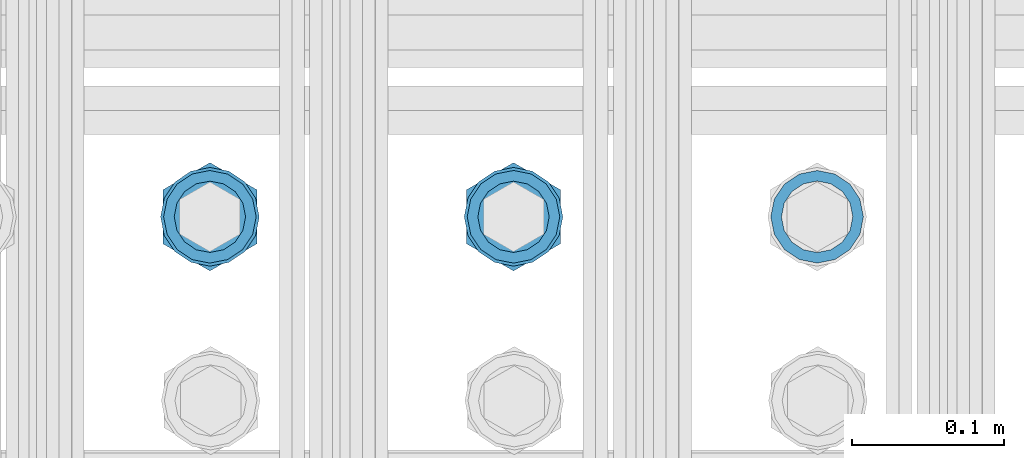
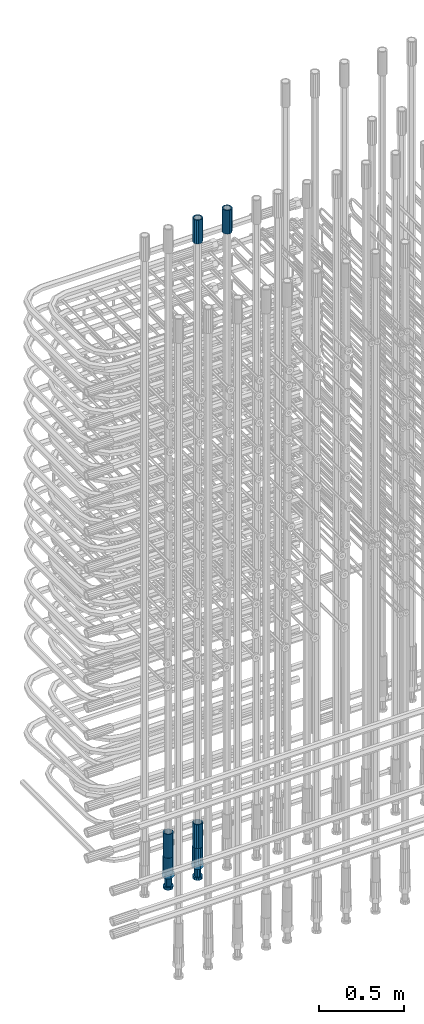
# One storey, part 33 of 177: 6 beams.
"""IFC2X3 building model written with IfcOpenShell, lengths in millimetres."""

from ifc_helpers import new_model, si_unit, frame, origin_with_axes, place, context, subcontext, project, spatial, faceted_brep, material, type_object, element, save


model = new_model("IFC2X3")

# Units and contexts
model_context_1 = context("Model", 3, precision=1e-05, world=origin_with_axes())
model_context_2 = context("Model", 3, precision=1e-05, world=origin_with_axes())
body_context = subcontext(model_context_2, "Body", "Model", "MODEL_VIEW")
ifc_project = project(units=[si_unit("LENGTHUNIT", "METRE", prefix="MILLI"), si_unit("AREAUNIT", "SQUARE_METRE"), si_unit("VOLUMEUNIT", "CUBIC_METRE"), si_unit("MASSUNIT", "GRAM", prefix="KILO"), si_unit("TIMEUNIT", "SECOND"), si_unit("PLANEANGLEUNIT", "RADIAN"), si_unit("SOLIDANGLEUNIT", "STERADIAN"), si_unit("THERMODYNAMICTEMPERATUREUNIT", "DEGREE_CELSIUS"), si_unit("LUMINOUSINTENSITYUNIT", "LUMEN")], contexts=[model_context_1])

# Site, building, storey
site_placement = place(None, origin_with_axes())
site = spatial("IfcSite", under=ifc_project, at=site_placement, CompositionType="ELEMENT")
building_placement = place(site_placement, origin_with_axes())
building = spatial("IfcBuilding", under=site, at=building_placement, Name="Undefined", CompositionType="ELEMENT")
storey_placement = place(building_placement, origin_with_axes())
storey = spatial("IfcBuildingStorey", under=building, at=storey_placement, Name="Undefined", CompositionType="ELEMENT", Elevation=0.0)

# Beams
ifc_material = material(Name="STEEL/S275")
beam_type_1 = type_object("IfcBeamType", PredefinedType="NOTDEFINED")
beam_1_placement = place(storey_placement, frame((2030635.50306268, 6205277.49272666, 23229.9858194793), z_axis=(1.0, 0.0, 0.0), x_axis=(0.0, 0.0, 1.0)))
element("IfcBeam", 1, at=beam_1_placement, inside=storey, type_object=beam_type_1, material=ifc_material, Name="AG40N", context=body_context, shape_type="Brep", body=[
    faceted_brep([(0.0, -23.5000000001164, -9.31322574615479e-10), (0.0, -21.7111690140155, 8.99306066054851), (170.0, -21.7111690140155, 8.99306066054851), (170.0, -23.5, 0.0), (0.0, -16.6170093578839, 16.6170093575493), (170.0, -16.6170093578839, 16.6170093575493), (0.0, -8.99306066057943, 21.7111690137535), (170.0, -8.99306066057943, 21.7111690137535), (0.0, 1.16415321826935e-10, 23.5), (170.0, 0.0, 23.5), (0.0, 8.99306066057943, 21.7111690137535), (170.0, 8.99306066057943, 21.7111690137535), (0.0, 16.6170093578839, 16.6170093575493), (170.0, 16.6170093578839, 16.6170093575493), (0.0, 21.7111690140155, 8.99306066054851), (170.0, 21.7111690140155, 8.99306066054851), (0.0, 23.5000000001164, -9.31322574615479e-10), (170.0, 23.5, 0.0), (0.0, 21.7111690140155, -8.99306066054851), (170.0, 21.7111690140155, -8.99306066054851), (0.0, 16.6170093578839, -16.6170093575493), (170.0, 16.6170093578839, -16.6170093575493), (0.0, 8.99306066057943, -21.7111690137535), (170.0, 8.99306066057943, -21.7111690137535), (0.0, 1.16415321826935e-10, -23.5000000009313), (170.0, 0.0, -23.5), (0.0, -8.99306066057943, -21.7111690137535), (170.0, -8.99306066057943, -21.7111690137535), (0.0, -16.6170093578839, -16.6170093575493), (170.0, -16.6170093578839, -16.6170093575493), (0.0, -21.7111690140155, -8.99306066054851), (170.0, -21.7111690140155, -8.99306066054851), (0.0, -30.5, 0.0), (0.0, -28.1783257415937, -11.6718446873128), (170.0, -28.1783257415937, -11.6718446873128), (170.0, -30.5, 0.0), (0.0, -21.5667568261888, -21.5667568258941), (170.0, -21.5667568261888, -21.5667568258941), (0.0, -11.6718446871346, -28.1783257415518), (170.0, -11.6718446871346, -28.1783257415518), (0.0, 0.0, -30.5), (170.0, 0.0, -30.5), (0.0, 11.6718446871346, -28.1783257415518), (170.0, 11.6718446871346, -28.1783257415518), (0.0, 21.5667568261888, -21.5667568258941), (170.0, 21.5667568261888, -21.5667568258941), (0.0, 28.1783257415937, -11.6718446873128), (170.0, 28.1783257415937, -11.6718446873128), (0.0, 30.5, 0.0), (170.0, 30.5, 0.0), (0.0, 28.1783257415937, 11.6718446873128), (170.0, 28.1783257415937, 11.6718446873128), (0.0, 21.5667568261888, 21.5667568258941), (170.0, 21.5667568261888, 21.5667568258941), (0.0, 11.6718446871346, 28.1783257415518), (170.0, 11.6718446871346, 28.1783257415518), (0.0, 0.0, 30.5), (170.0, 0.0, 30.5), (0.0, -11.6718446871346, 28.1783257415518), (170.0, -11.6718446871346, 28.1783257415518), (0.0, -21.5667568261888, 21.5667568258941), (170.0, -21.5667568261888, 21.5667568258941), (0.0, -28.1783257415937, 11.6718446873128), (170.0, -28.1783257415937, 11.6718446873128)], [[[0, 1, 2, 3]], [[1, 4, 5, 2]], [[4, 6, 7, 5]], [[6, 8, 9, 7]], [[8, 10, 11, 9]], [[10, 12, 13, 11]], [[12, 14, 15, 13]], [[14, 16, 17, 15]], [[16, 18, 19, 17]], [[18, 20, 21, 19]], [[20, 22, 23, 21]], [[22, 24, 25, 23]], [[24, 26, 27, 25]], [[26, 28, 29, 27]], [[28, 30, 31, 29]], [[30, 0, 3, 31]], [[32, 33, 34, 35]], [[33, 36, 37, 34]], [[36, 38, 39, 37]], [[38, 40, 41, 39]], [[40, 42, 43, 41]], [[42, 44, 45, 43]], [[44, 46, 47, 45]], [[46, 48, 49, 47]], [[48, 50, 51, 49]], [[50, 52, 53, 51]], [[52, 54, 55, 53]], [[54, 56, 57, 55]], [[56, 58, 59, 57]], [[58, 60, 61, 59]], [[60, 62, 63, 61]], [[62, 32, 35, 63]], [[37, 39, 41, 43, 45, 47, 49, 51, 53, 55, 57, 59, 61, 63, 35, 34], [5, 7, 9, 11, 13, 15, 17, 19, 21, 23, 25, 27, 29, 31, 3, 2]], [[62, 60, 58, 56, 54, 52, 50, 48, 46, 44, 42, 40, 38, 36, 33, 32], [30, 28, 26, 24, 22, 20, 18, 16, 14, 12, 10, 8, 6, 4, 1, 0]]]),
])
beam_2_placement = place(storey_placement, frame((2030435.5030627, 6205277.49272666, 19060.966800425), z_axis=(-1.0, 0.0, 0.0), x_axis=(0.0, 0.0, -1.0)))
element("IfcBeam", 2, at=beam_2_placement, inside=storey, type_object=beam_type_1, material=ifc_material, Name="AG40N", context=body_context, shape_type="Brep", body=[
    faceted_brep([(0.0, -23.5000000001164, -9.31322574615479e-10), (0.0, -21.7111690140155, 8.99306066054851), (170.0, -21.7111690140155, 8.99306066054851), (170.0, -23.5, 0.0), (0.0, -16.6170093578839, 16.6170093575493), (170.0, -16.6170093578839, 16.6170093575493), (0.0, -8.99306066057943, 21.7111690137535), (170.0, -8.99306066057943, 21.7111690137535), (0.0, 1.16415321826935e-10, 23.5), (170.0, 0.0, 23.5), (0.0, 8.99306066057943, 21.7111690137535), (170.0, 8.99306066057943, 21.7111690137535), (0.0, 16.6170093578839, 16.6170093575493), (170.0, 16.6170093578839, 16.6170093575493), (0.0, 21.7111690140155, 8.99306066054851), (170.0, 21.7111690140155, 8.99306066054851), (0.0, 23.5000000001164, -9.31322574615479e-10), (170.0, 23.5, 0.0), (0.0, 21.7111690140155, -8.99306066054851), (170.0, 21.7111690140155, -8.99306066054851), (0.0, 16.6170093578839, -16.6170093575493), (170.0, 16.6170093578839, -16.6170093575493), (0.0, 8.99306066057943, -21.7111690137535), (170.0, 8.99306066057943, -21.7111690137535), (0.0, 1.16415321826935e-10, -23.5000000009313), (170.0, 0.0, -23.5), (0.0, -8.99306066057943, -21.7111690137535), (170.0, -8.99306066057943, -21.7111690137535), (0.0, -16.6170093578839, -16.6170093575493), (170.0, -16.6170093578839, -16.6170093575493), (0.0, -21.7111690140155, -8.99306066054851), (170.0, -21.7111690140155, -8.99306066054851), (0.0, -30.5, 0.0), (0.0, -28.1783257415937, -11.6718446873128), (170.0, -28.1783257415937, -11.6718446873128), (170.0, -30.5, 0.0), (0.0, -21.5667568261888, -21.5667568258941), (170.0, -21.5667568261888, -21.5667568258941), (0.0, -11.6718446871346, -28.1783257415518), (170.0, -11.6718446871346, -28.1783257415518), (0.0, 0.0, -30.5), (170.0, 0.0, -30.5), (0.0, 11.6718446871346, -28.1783257415518), (170.0, 11.6718446871346, -28.1783257415518), (0.0, 21.5667568261888, -21.5667568258941), (170.0, 21.5667568261888, -21.5667568258941), (0.0, 28.1783257415937, -11.6718446873128), (170.0, 28.1783257415937, -11.6718446873128), (0.0, 30.5, 0.0), (170.0, 30.5, 0.0), (0.0, 28.1783257415937, 11.6718446873128), (170.0, 28.1783257415937, 11.6718446873128), (0.0, 21.5667568261888, 21.5667568258941), (170.0, 21.5667568261888, 21.5667568258941), (0.0, 11.6718446871346, 28.1783257415518), (170.0, 11.6718446871346, 28.1783257415518), (0.0, 0.0, 30.5), (170.0, 0.0, 30.5), (0.0, -11.6718446871346, 28.1783257415518), (170.0, -11.6718446871346, 28.1783257415518), (0.0, -21.5667568261888, 21.5667568258941), (170.0, -21.5667568261888, 21.5667568258941), (0.0, -28.1783257415937, 11.6718446873128), (170.0, -28.1783257415937, 11.6718446873128)], [[[0, 1, 2, 3]], [[1, 4, 5, 2]], [[4, 6, 7, 5]], [[6, 8, 9, 7]], [[8, 10, 11, 9]], [[10, 12, 13, 11]], [[12, 14, 15, 13]], [[14, 16, 17, 15]], [[16, 18, 19, 17]], [[18, 20, 21, 19]], [[20, 22, 23, 21]], [[22, 24, 25, 23]], [[24, 26, 27, 25]], [[26, 28, 29, 27]], [[28, 30, 31, 29]], [[30, 0, 3, 31]], [[32, 33, 34, 35]], [[33, 36, 37, 34]], [[36, 38, 39, 37]], [[38, 40, 41, 39]], [[40, 42, 43, 41]], [[42, 44, 45, 43]], [[44, 46, 47, 45]], [[46, 48, 49, 47]], [[48, 50, 51, 49]], [[50, 52, 53, 51]], [[52, 54, 55, 53]], [[54, 56, 57, 55]], [[56, 58, 59, 57]], [[58, 60, 61, 59]], [[60, 62, 63, 61]], [[62, 32, 35, 63]], [[37, 39, 41, 43, 45, 47, 49, 51, 53, 55, 57, 59, 61, 63, 35, 34], [5, 7, 9, 11, 13, 15, 17, 19, 21, 23, 25, 27, 29, 31, 3, 2]], [[62, 60, 58, 56, 54, 52, 50, 48, 46, 44, 42, 40, 38, 36, 33, 32], [30, 28, 26, 24, 22, 20, 18, 16, 14, 12, 10, 8, 6, 4, 1, 0]]]),
])
beam_3_placement = place(storey_placement, frame((2030435.50306268, 6205277.49272666, 23229.9858194793), z_axis=(1.0, 0.0, 0.0), x_axis=(0.0, 0.0, 1.0)))
element("IfcBeam", 3, at=beam_3_placement, inside=storey, type_object=beam_type_1, material=ifc_material, Name="AG40N", context=body_context, shape_type="Brep", body=[
    faceted_brep([(0.0, -23.5000000001164, -9.31322574615479e-10), (0.0, -21.7111690140155, 8.99306066054851), (170.0, -21.7111690140155, 8.99306066054851), (170.0, -23.5, 0.0), (0.0, -16.6170093578839, 16.6170093575493), (170.0, -16.6170093578839, 16.6170093575493), (0.0, -8.99306066057943, 21.7111690137535), (170.0, -8.99306066057943, 21.7111690137535), (0.0, 1.16415321826935e-10, 23.5), (170.0, 0.0, 23.5), (0.0, 8.99306066057943, 21.7111690137535), (170.0, 8.99306066057943, 21.7111690137535), (0.0, 16.6170093578839, 16.6170093575493), (170.0, 16.6170093578839, 16.6170093575493), (0.0, 21.7111690140155, 8.99306066054851), (170.0, 21.7111690140155, 8.99306066054851), (0.0, 23.5000000001164, -9.31322574615479e-10), (170.0, 23.5, 0.0), (0.0, 21.7111690140155, -8.99306066054851), (170.0, 21.7111690140155, -8.99306066054851), (0.0, 16.6170093578839, -16.6170093575493), (170.0, 16.6170093578839, -16.6170093575493), (0.0, 8.99306066057943, -21.7111690137535), (170.0, 8.99306066057943, -21.7111690137535), (0.0, 1.16415321826935e-10, -23.5000000009313), (170.0, 0.0, -23.5), (0.0, -8.99306066057943, -21.7111690137535), (170.0, -8.99306066057943, -21.7111690137535), (0.0, -16.6170093578839, -16.6170093575493), (170.0, -16.6170093578839, -16.6170093575493), (0.0, -21.7111690140155, -8.99306066054851), (170.0, -21.7111690140155, -8.99306066054851), (0.0, -30.5, 0.0), (0.0, -28.1783257415937, -11.6718446873128), (170.0, -28.1783257415937, -11.6718446873128), (170.0, -30.5, 0.0), (0.0, -21.5667568261888, -21.5667568258941), (170.0, -21.5667568261888, -21.5667568258941), (0.0, -11.6718446871346, -28.1783257415518), (170.0, -11.6718446871346, -28.1783257415518), (0.0, 0.0, -30.5), (170.0, 0.0, -30.5), (0.0, 11.6718446871346, -28.1783257415518), (170.0, 11.6718446871346, -28.1783257415518), (0.0, 21.5667568261888, -21.5667568258941), (170.0, 21.5667568261888, -21.5667568258941), (0.0, 28.1783257415937, -11.6718446873128), (170.0, 28.1783257415937, -11.6718446873128), (0.0, 30.5, 0.0), (170.0, 30.5, 0.0), (0.0, 28.1783257415937, 11.6718446873128), (170.0, 28.1783257415937, 11.6718446873128), (0.0, 21.5667568261888, 21.5667568258941), (170.0, 21.5667568261888, 21.5667568258941), (0.0, 11.6718446871346, 28.1783257415518), (170.0, 11.6718446871346, 28.1783257415518), (0.0, 0.0, 30.5), (170.0, 0.0, 30.5), (0.0, -11.6718446871346, 28.1783257415518), (170.0, -11.6718446871346, 28.1783257415518), (0.0, -21.5667568261888, 21.5667568258941), (170.0, -21.5667568261888, 21.5667568258941), (0.0, -28.1783257415937, 11.6718446873128), (170.0, -28.1783257415937, 11.6718446873128)], [[[0, 1, 2, 3]], [[1, 4, 5, 2]], [[4, 6, 7, 5]], [[6, 8, 9, 7]], [[8, 10, 11, 9]], [[10, 12, 13, 11]], [[12, 14, 15, 13]], [[14, 16, 17, 15]], [[16, 18, 19, 17]], [[18, 20, 21, 19]], [[20, 22, 23, 21]], [[22, 24, 25, 23]], [[24, 26, 27, 25]], [[26, 28, 29, 27]], [[28, 30, 31, 29]], [[30, 0, 3, 31]], [[32, 33, 34, 35]], [[33, 36, 37, 34]], [[36, 38, 39, 37]], [[38, 40, 41, 39]], [[40, 42, 43, 41]], [[42, 44, 45, 43]], [[44, 46, 47, 45]], [[46, 48, 49, 47]], [[48, 50, 51, 49]], [[50, 52, 53, 51]], [[52, 54, 55, 53]], [[54, 56, 57, 55]], [[56, 58, 59, 57]], [[58, 60, 61, 59]], [[60, 62, 63, 61]], [[62, 32, 35, 63]], [[37, 39, 41, 43, 45, 47, 49, 51, 53, 55, 57, 59, 61, 63, 35, 34], [5, 7, 9, 11, 13, 15, 17, 19, 21, 23, 25, 27, 29, 31, 3, 2]], [[62, 60, 58, 56, 54, 52, 50, 48, 46, 44, 42, 40, 38, 36, 33, 32], [30, 28, 26, 24, 22, 20, 18, 16, 14, 12, 10, 8, 6, 4, 1, 0]]]),
])
beam_4_placement = place(storey_placement, frame((2030235.5030627, 6205277.49272665, 19060.9668004261), z_axis=(-1.0, 0.0, 0.0), x_axis=(0.0, 0.0, -1.0)))
element("IfcBeam", 4, at=beam_4_placement, inside=storey, type_object=beam_type_1, material=ifc_material, Name="AG40N", context=body_context, shape_type="Brep", body=[
    faceted_brep([(0.0, -23.5000000001164, -9.31322574615479e-10), (0.0, -21.7111690140155, 8.99306066054851), (170.0, -21.7111690140155, 8.99306066054851), (170.0, -23.5, 0.0), (0.0, -16.6170093578839, 16.6170093575493), (170.0, -16.6170093578839, 16.6170093575493), (0.0, -8.99306066057943, 21.7111690137535), (170.0, -8.99306066057943, 21.7111690137535), (0.0, 1.16415321826935e-10, 23.5), (170.0, 0.0, 23.5), (0.0, 8.99306066057943, 21.7111690137535), (170.0, 8.99306066057943, 21.7111690137535), (0.0, 16.6170093578839, 16.6170093575493), (170.0, 16.6170093578839, 16.6170093575493), (0.0, 21.7111690140155, 8.99306066054851), (170.0, 21.7111690140155, 8.99306066054851), (0.0, 23.5000000001164, -9.31322574615479e-10), (170.0, 23.5, 0.0), (0.0, 21.7111690140155, -8.99306066054851), (170.0, 21.7111690140155, -8.99306066054851), (0.0, 16.6170093578839, -16.6170093575493), (170.0, 16.6170093578839, -16.6170093575493), (0.0, 8.99306066057943, -21.7111690137535), (170.0, 8.99306066057943, -21.7111690137535), (0.0, 1.16415321826935e-10, -23.5000000009313), (170.0, 0.0, -23.5), (0.0, -8.99306066057943, -21.7111690137535), (170.0, -8.99306066057943, -21.7111690137535), (0.0, -16.6170093578839, -16.6170093575493), (170.0, -16.6170093578839, -16.6170093575493), (0.0, -21.7111690140155, -8.99306066054851), (170.0, -21.7111690140155, -8.99306066054851), (0.0, -30.5, 0.0), (0.0, -28.1783257415937, -11.6718446873128), (170.0, -28.1783257415937, -11.6718446873128), (170.0, -30.5, 0.0), (0.0, -21.5667568261888, -21.5667568258941), (170.0, -21.5667568261888, -21.5667568258941), (0.0, -11.6718446871346, -28.1783257415518), (170.0, -11.6718446871346, -28.1783257415518), (0.0, 0.0, -30.5), (170.0, 0.0, -30.5), (0.0, 11.6718446871346, -28.1783257415518), (170.0, 11.6718446871346, -28.1783257415518), (0.0, 21.5667568261888, -21.5667568258941), (170.0, 21.5667568261888, -21.5667568258941), (0.0, 28.1783257415937, -11.6718446873128), (170.0, 28.1783257415937, -11.6718446873128), (0.0, 30.5, 0.0), (170.0, 30.5, 0.0), (0.0, 28.1783257415937, 11.6718446873128), (170.0, 28.1783257415937, 11.6718446873128), (0.0, 21.5667568261888, 21.5667568258941), (170.0, 21.5667568261888, 21.5667568258941), (0.0, 11.6718446871346, 28.1783257415518), (170.0, 11.6718446871346, 28.1783257415518), (0.0, 0.0, 30.5), (170.0, 0.0, 30.5), (0.0, -11.6718446871346, 28.1783257415518), (170.0, -11.6718446871346, 28.1783257415518), (0.0, -21.5667568261888, 21.5667568258941), (170.0, -21.5667568261888, 21.5667568258941), (0.0, -28.1783257415937, 11.6718446873128), (170.0, -28.1783257415937, 11.6718446873128)], [[[0, 1, 2, 3]], [[1, 4, 5, 2]], [[4, 6, 7, 5]], [[6, 8, 9, 7]], [[8, 10, 11, 9]], [[10, 12, 13, 11]], [[12, 14, 15, 13]], [[14, 16, 17, 15]], [[16, 18, 19, 17]], [[18, 20, 21, 19]], [[20, 22, 23, 21]], [[22, 24, 25, 23]], [[24, 26, 27, 25]], [[26, 28, 29, 27]], [[28, 30, 31, 29]], [[30, 0, 3, 31]], [[32, 33, 34, 35]], [[33, 36, 37, 34]], [[36, 38, 39, 37]], [[38, 40, 41, 39]], [[40, 42, 43, 41]], [[42, 44, 45, 43]], [[44, 46, 47, 45]], [[46, 48, 49, 47]], [[48, 50, 51, 49]], [[50, 52, 53, 51]], [[52, 54, 55, 53]], [[54, 56, 57, 55]], [[56, 58, 59, 57]], [[58, 60, 61, 59]], [[60, 62, 63, 61]], [[62, 32, 35, 63]], [[37, 39, 41, 43, 45, 47, 49, 51, 53, 55, 57, 59, 61, 63, 35, 34], [5, 7, 9, 11, 13, 15, 17, 19, 21, 23, 25, 27, 29, 31, 3, 2]], [[62, 60, 58, 56, 54, 52, 50, 48, 46, 44, 42, 40, 38, 36, 33, 32], [30, 28, 26, 24, 22, 20, 18, 16, 14, 12, 10, 8, 6, 4, 1, 0]]]),
])
beam_type_2 = type_object("IfcBeamType", Name="ROD65", PredefinedType="NOTDEFINED")
beam_5_placement = place(storey_placement, frame((2030435.50306269, 6205277.49272666, 18890.966800425), z_axis=(-1.0, 0.0, 0.0), x_axis=(0.0, 0.0, -1.0)))
element("IfcBeam", 5, at=beam_5_placement, inside=storey, type_object=beam_type_2, material=ifc_material, Name="AGB40", ObjectType="ROD65", context=body_context, shape_type="Brep", body=[
    faceted_brep([(117.0, 8.17543110251427, 30.873805644922), (117.0, 17.8250000001863, 30.873805644922), (117.0, 22.0056958701462, 23.6326279877685), (117.0, 12.4372115517035, 30.0260848065373), (117.0, -17.8250000001863, 30.873805644922), (150.200000000186, -17.8250000001863, 30.873805644922), (150.200000000186, 17.8250000001863, 30.873805644922), (117.0, -8.17543110251427, 30.873805644922), (117.0, -12.4372115517035, 30.0260848065373), (117.0, -22.0056958701462, 23.6326279877685), (117.0, -35.6500000003725, 0.0), (150.200000000186, -35.6500000003725, 0.0), (117.0, -30.8443150008097, 8.32369058486074), (117.0, -32.5, 0.0), (117.0, -30.8443150008097, -8.32369058462791), (117.0, -17.8250000001863, -30.873805644922), (150.200000000186, -17.8250000001863, -30.873805644922), (117.0, -22.0056958701462, -23.6326279877685), (117.0, -12.4372115517035, -30.0260848065373), (117.0, -8.17543110251427, -30.873805644922), (117.0, 17.8250000001863, -30.873805644922), (150.200000000186, 17.8250000001863, -30.873805644922), (117.0, 8.17543110251427, -30.873805644922), (117.0, 22.0056958701462, -23.6326279877685), (117.0, 12.4372115517035, -30.0260848065373), (117.0, 35.6500000003725, 0.0), (150.200000000186, 35.6500000003725, 0.0), (117.0, 30.8443150008097, -8.32369058486074), (117.0, 30.8443150008097, 8.32369058462791), (117.0, 32.5, 0.0), (0.0, -22.9809703892097, 22.9809703885621), (0.0, -30.0260848058388, 12.4372115518636), (117.0, -30.0260848067701, 12.4372115519363), (117.0, -22.9809703882784, 22.9809703885112), (-2.3283064365387e-10, 22.9809703892097, -22.9809703885639), (-4.65661287307739e-10, 30.0260848077014, -12.4372115518672), (117.0, 30.0260848067701, -12.4372115519363), (117.0, 22.9809703882784, -22.9809703885112), (-2.3283064365387e-10, -30.0260848067701, -12.4372115518672), (-2.3283064365387e-10, -22.9809703892097, -22.9809703885621), (117.0, -22.9809703882784, -22.9809703885112), (117.0, -30.0260848067701, -12.4372115519363), (-2.3283064365387e-10, -12.4372115507722, 30.0260848066137), (-2.3283064365387e-10, 9.31322574615479e-10, 32.4999999999982), (-2.3283064365387e-10, 12.4372115526348, 30.0260848066137), (0.0, 22.9809703892097, 22.9809703885621), (-2.3283064365387e-10, 30.0260848077014, 12.4372115518636), (-2.3283064365387e-10, 32.5, 0.0), (-2.3283064365387e-10, 12.4372115526348, -30.0260848066173), (-2.3283064365387e-10, 9.31322574615479e-10, -32.5), (-2.3283064365387e-10, -12.4372115517035, -30.0260848066173), (-4.65661287307739e-10, -32.4999999990687, -1.81898940354586e-12), (117.0, 22.9809703882784, 22.9809703885112), (117.0, 30.0260848067701, 12.4372115519363), (117.0, 0.0, -32.5), (117.0, 0.0, 32.5), (150.200000000186, 10.5, -18.1865334794857), (150.200000000186, 0.0, -21.0), (150.200000000186, -10.5, -18.1865334794857), (150.200000000186, -18.18653347902, -10.5), (150.200000000186, -21.0, 0.0), (150.200000000186, -18.18653347902, 10.5), (150.200000000186, -10.5, 18.1865334794857), (150.200000000186, 0.0, 21.0), (150.200000000186, 10.5, 18.1865334794857), (150.200000000186, 18.18653347902, 10.5), (150.200000000186, 21.0, 0.0), (150.200000000186, 18.18653347902, -10.5), (210.980000000447, -10.5, -18.1865334794857), (210.980000000447, 0.0, -21.0), (210.980000000447, -18.18653347902, -10.5), (210.980000000447, -21.0, 0.0), (210.980000000447, -18.18653347902, 10.5), (210.980000000447, -10.5, 18.1865334794857), (210.980000000447, 0.0, 21.0), (210.980000000447, 10.5, 18.1865334794857), (210.980000000447, 18.18653347902, 10.5), (210.980000000447, 21.0, 0.0), (210.980000000447, 18.18653347902, -10.5), (210.980000000447, 10.5, -18.1865334794857), (211.001368442696, -27.7269937992096, -11.491116326768), (211.003082550167, -21.2238094303757, -21.223815418547), (231.002518367059, -21.2131944671273, -21.2132004550658), (231.000804259587, -27.7163788359612, -11.4805013632867), (211.001368440451, -11.4911085031927, -27.7269970395137), (231.000804257343, -11.4804935399443, -27.7163820760325), (210.996487071217, -0.0106065049767494, -30.0106107392348), (230.995922888109, 8.45827162265778e-06, -29.9999957757536), (210.989181586672, 11.46989420522, -27.7269970329944), (230.988617403564, 11.4805091684684, -27.7163820695132), (210.980564180623, 21.2025914648548, -21.2238154064398), (230.979999997515, 21.2132064281031, -21.2132004429586), (210.971946775022, 27.7057703435421, -11.4911163107026), (230.971382591913, 27.7163853067905, -11.4805013472214), (210.96464129175, 29.9893808094785, -0.0106149562634528), (230.964077108642, 29.9999957727268, 7.21774995326996e-09), (210.959759924415, 27.7057638689876, 11.4698863970116), (230.959195741307, 27.7163788322359, 11.4805013604928), (210.958045816944, 21.2025795001537, 21.2025854887906), (230.957481633835, 21.213194463402, 21.2132004522718), (210.95975992666, 11.4698785729706, 27.7057671097573), (230.959195743551, 11.480493536219, 27.7163820732385), (210.964641295894, -0.010623425245285, 29.9893808094785), (230.964077112785, -8.46199691295624e-06, 29.9999957729597), (210.971946780439, -11.4911241354421, 27.705767103238), (230.97138259733, -11.4805091721937, 27.7163820667192), (210.980564186488, -21.2238213950768, 21.2025854766835), (230.980000003379, -21.2132064318284, 21.2132004401647), (210.989181592089, -27.7270002737641, 11.4698863809463), (230.988617408981, -27.7163853105158, 11.4805013444275), (210.996487075361, -30.0106107397005, -0.0106149734929204), (230.995922892253, -29.9999957764521, -1.00117176771164e-08)], [[[0, 1, 2, 3]], [[4, 5, 6, 1, 0, 7]], [[4, 7, 8, 9]], [[10, 11, 5, 4, 9, 12]], [[10, 12, 13, 14]], [[15, 16, 11, 10, 14, 17]], [[15, 17, 18, 19]], [[20, 21, 16, 15, 19, 22]], [[23, 20, 22, 24]], [[25, 26, 21, 20, 23, 27]], [[28, 25, 27, 29]], [[30, 31, 32, 33]], [[34, 35, 36, 37]], [[38, 39, 40, 41]], [[31, 30, 42, 43, 44, 45, 46, 47, 35, 34, 48, 49, 50, 39, 38, 51]], [[46, 45, 52, 53]], [[29, 47, 46, 53, 28]], [[27, 36, 35, 47, 29]], [[23, 37, 36, 27]], [[24, 48, 34, 37, 23]], [[22, 54, 49, 48, 24]], [[19, 54, 22]], [[18, 50, 49, 54, 19]], [[17, 40, 39, 50, 18]], [[14, 41, 40, 17]], [[13, 51, 38, 41, 14]], [[12, 32, 31, 51, 13]], [[9, 33, 32, 12]], [[8, 42, 30, 33, 9]], [[7, 55, 43, 42, 8]], [[0, 55, 7]], [[3, 44, 43, 55, 0]], [[2, 52, 45, 44, 3]], [[28, 53, 52, 2]], [[1, 6, 26, 25, 28, 2]], [[5, 11, 16, 21, 26, 6], [56, 57, 58, 59, 60, 61, 62, 63, 64, 65, 66, 67]], [[68, 58, 57, 69]], [[70, 59, 58, 68]], [[71, 60, 59, 70]], [[72, 61, 60, 71]], [[73, 62, 61, 72]], [[74, 63, 62, 73]], [[75, 64, 63, 74]], [[76, 65, 64, 75]], [[77, 66, 65, 76]], [[78, 67, 66, 77]], [[79, 56, 67, 78]], [[69, 57, 56, 79]], [[80, 81, 82, 83]], [[81, 84, 85, 82]], [[84, 86, 87, 85]], [[86, 88, 89, 87]], [[88, 90, 91, 89]], [[90, 92, 93, 91]], [[92, 94, 95, 93]], [[94, 96, 97, 95]], [[96, 98, 99, 97]], [[98, 100, 101, 99]], [[100, 102, 103, 101]], [[102, 104, 105, 103]], [[104, 106, 107, 105]], [[106, 108, 109, 107]], [[108, 110, 111, 109]], [[82, 85, 87, 89, 91, 93, 95, 97, 99, 101, 103, 105, 107, 109, 111, 83]], [[110, 80, 83, 111]], [[108, 106, 104, 102, 100, 98, 96, 94, 92, 90, 88, 86, 84, 81, 80, 110], [78, 77, 76, 75, 74, 73, 72, 71, 70, 68, 69, 79]]]),
])
beam_6_placement = place(storey_placement, frame((2030235.50306269, 6205277.49272665, 18890.9668004261), z_axis=(-1.0, 0.0, 0.0), x_axis=(0.0, 0.0, -1.0)))
element("IfcBeam", 6, at=beam_6_placement, inside=storey, type_object=beam_type_2, material=ifc_material, Name="AGB40", ObjectType="ROD65", context=body_context, shape_type="Brep", body=[
    faceted_brep([(117.0, 8.17543110251427, 30.873805644922), (117.0, 17.8250000001863, 30.873805644922), (117.0, 22.0056958701462, 23.6326279877685), (117.0, 12.4372115517035, 30.0260848065373), (117.0, -17.8250000001863, 30.873805644922), (150.200000000186, -17.8250000001863, 30.873805644922), (150.200000000186, 17.8250000001863, 30.873805644922), (117.0, -8.17543110251427, 30.873805644922), (117.0, -12.4372115517035, 30.0260848065373), (117.0, -22.0056958701462, 23.6326279877685), (117.0, -35.6500000003725, 0.0), (150.200000000186, -35.6500000003725, 0.0), (117.0, -30.8443150008097, 8.32369058486074), (117.0, -32.5, 0.0), (117.0, -30.8443150008097, -8.32369058462791), (117.0, -17.8250000001863, -30.873805644922), (150.200000000186, -17.8250000001863, -30.873805644922), (117.0, -22.0056958701462, -23.6326279877685), (117.0, -12.4372115517035, -30.0260848065373), (117.0, -8.17543110251427, -30.873805644922), (117.0, 17.8250000001863, -30.873805644922), (150.200000000186, 17.8250000001863, -30.873805644922), (117.0, 8.17543110251427, -30.873805644922), (117.0, 22.0056958701462, -23.6326279877685), (117.0, 12.4372115517035, -30.0260848065373), (117.0, 35.6500000003725, 0.0), (150.200000000186, 35.6500000003725, 0.0), (117.0, 30.8443150008097, -8.32369058486074), (117.0, 30.8443150008097, 8.32369058462791), (117.0, 32.5, 0.0), (0.0, -22.9809703892097, 22.9809703885621), (0.0, -30.0260848058388, 12.4372115518636), (117.0, -30.0260848067701, 12.4372115519363), (117.0, -22.9809703882784, 22.9809703885112), (-2.3283064365387e-10, 22.9809703892097, -22.9809703885639), (-4.65661287307739e-10, 30.0260848077014, -12.4372115518672), (117.0, 30.0260848067701, -12.4372115519363), (117.0, 22.9809703882784, -22.9809703885112), (-2.3283064365387e-10, -30.0260848067701, -12.4372115518672), (-2.3283064365387e-10, -22.9809703892097, -22.9809703885621), (117.0, -22.9809703882784, -22.9809703885112), (117.0, -30.0260848067701, -12.4372115519363), (-2.3283064365387e-10, -12.4372115507722, 30.0260848066137), (-2.3283064365387e-10, 9.31322574615479e-10, 32.4999999999982), (-2.3283064365387e-10, 12.4372115526348, 30.0260848066137), (0.0, 22.9809703892097, 22.9809703885621), (-2.3283064365387e-10, 30.0260848077014, 12.4372115518636), (-2.3283064365387e-10, 32.5, 0.0), (-2.3283064365387e-10, 12.4372115526348, -30.0260848066173), (-2.3283064365387e-10, 9.31322574615479e-10, -32.5), (-2.3283064365387e-10, -12.4372115517035, -30.0260848066173), (-4.65661287307739e-10, -32.4999999990687, -1.81898940354586e-12), (117.0, 22.9809703882784, 22.9809703885112), (117.0, 30.0260848067701, 12.4372115519363), (117.0, 0.0, -32.5), (117.0, 0.0, 32.5), (150.200000000186, 10.5, -18.1865334794857), (150.200000000186, 0.0, -21.0), (150.200000000186, -10.5, -18.1865334794857), (150.200000000186, -18.18653347902, -10.5), (150.200000000186, -21.0, 0.0), (150.200000000186, -18.18653347902, 10.5), (150.200000000186, -10.5, 18.1865334794857), (150.200000000186, 0.0, 21.0), (150.200000000186, 10.5, 18.1865334794857), (150.200000000186, 18.18653347902, 10.5), (150.200000000186, 21.0, 0.0), (150.200000000186, 18.18653347902, -10.5), (210.980000000447, -10.5, -18.1865334794857), (210.980000000447, 0.0, -21.0), (210.980000000447, -18.18653347902, -10.5), (210.980000000447, -21.0, 0.0), (210.980000000447, -18.18653347902, 10.5), (210.980000000447, -10.5, 18.1865334794857), (210.980000000447, 0.0, 21.0), (210.980000000447, 10.5, 18.1865334794857), (210.980000000447, 18.18653347902, 10.5), (210.980000000447, 21.0, 0.0), (210.980000000447, 18.18653347902, -10.5), (210.980000000447, 10.5, -18.1865334794857), (211.001368442696, -27.7269937992096, -11.491116326768), (211.003082550167, -21.2238094303757, -21.223815418547), (231.002518367059, -21.2131944671273, -21.2132004550658), (231.000804259587, -27.7163788359612, -11.4805013632867), (211.001368440451, -11.4911085031927, -27.7269970395137), (231.000804257343, -11.4804935399443, -27.7163820760325), (210.996487071217, -0.0106065049767494, -30.0106107392348), (230.995922888109, 8.45827162265778e-06, -29.9999957757536), (210.989181586672, 11.46989420522, -27.7269970329944), (230.988617403564, 11.4805091684684, -27.7163820695132), (210.980564180623, 21.2025914648548, -21.2238154064398), (230.979999997515, 21.2132064281031, -21.2132004429586), (210.971946775022, 27.7057703435421, -11.4911163107026), (230.971382591913, 27.7163853067905, -11.4805013472214), (210.96464129175, 29.9893808094785, -0.0106149562634528), (230.964077108642, 29.9999957727268, 7.21774995326996e-09), (210.959759924415, 27.7057638689876, 11.4698863970116), (230.959195741307, 27.7163788322359, 11.4805013604928), (210.958045816944, 21.2025795001537, 21.2025854887906), (230.957481633835, 21.213194463402, 21.2132004522718), (210.95975992666, 11.4698785729706, 27.7057671097573), (230.959195743551, 11.480493536219, 27.7163820732385), (210.964641295894, -0.010623425245285, 29.9893808094785), (230.964077112785, -8.46199691295624e-06, 29.9999957729597), (210.971946780439, -11.4911241354421, 27.705767103238), (230.97138259733, -11.4805091721937, 27.7163820667192), (210.980564186488, -21.2238213950768, 21.2025854766835), (230.980000003379, -21.2132064318284, 21.2132004401647), (210.989181592089, -27.7270002737641, 11.4698863809463), (230.988617408981, -27.7163853105158, 11.4805013444275), (210.996487075361, -30.0106107397005, -0.0106149734929204), (230.995922892253, -29.9999957764521, -1.00117176771164e-08)], [[[0, 1, 2, 3]], [[4, 5, 6, 1, 0, 7]], [[4, 7, 8, 9]], [[10, 11, 5, 4, 9, 12]], [[10, 12, 13, 14]], [[15, 16, 11, 10, 14, 17]], [[15, 17, 18, 19]], [[20, 21, 16, 15, 19, 22]], [[23, 20, 22, 24]], [[25, 26, 21, 20, 23, 27]], [[28, 25, 27, 29]], [[30, 31, 32, 33]], [[34, 35, 36, 37]], [[38, 39, 40, 41]], [[31, 30, 42, 43, 44, 45, 46, 47, 35, 34, 48, 49, 50, 39, 38, 51]], [[46, 45, 52, 53]], [[29, 47, 46, 53, 28]], [[27, 36, 35, 47, 29]], [[23, 37, 36, 27]], [[24, 48, 34, 37, 23]], [[22, 54, 49, 48, 24]], [[19, 54, 22]], [[18, 50, 49, 54, 19]], [[17, 40, 39, 50, 18]], [[14, 41, 40, 17]], [[13, 51, 38, 41, 14]], [[12, 32, 31, 51, 13]], [[9, 33, 32, 12]], [[8, 42, 30, 33, 9]], [[7, 55, 43, 42, 8]], [[0, 55, 7]], [[3, 44, 43, 55, 0]], [[2, 52, 45, 44, 3]], [[28, 53, 52, 2]], [[1, 6, 26, 25, 28, 2]], [[5, 11, 16, 21, 26, 6], [56, 57, 58, 59, 60, 61, 62, 63, 64, 65, 66, 67]], [[68, 58, 57, 69]], [[70, 59, 58, 68]], [[71, 60, 59, 70]], [[72, 61, 60, 71]], [[73, 62, 61, 72]], [[74, 63, 62, 73]], [[75, 64, 63, 74]], [[76, 65, 64, 75]], [[77, 66, 65, 76]], [[78, 67, 66, 77]], [[79, 56, 67, 78]], [[69, 57, 56, 79]], [[80, 81, 82, 83]], [[81, 84, 85, 82]], [[84, 86, 87, 85]], [[86, 88, 89, 87]], [[88, 90, 91, 89]], [[90, 92, 93, 91]], [[92, 94, 95, 93]], [[94, 96, 97, 95]], [[96, 98, 99, 97]], [[98, 100, 101, 99]], [[100, 102, 103, 101]], [[102, 104, 105, 103]], [[104, 106, 107, 105]], [[106, 108, 109, 107]], [[108, 110, 111, 109]], [[82, 85, 87, 89, 91, 93, 95, 97, 99, 101, 103, 105, 107, 109, 111, 83]], [[110, 80, 83, 111]], [[108, 106, 104, 102, 100, 98, 96, 94, 92, 90, 88, 86, 84, 81, 80, 110], [78, 77, 76, 75, 74, 73, 72, 71, 70, 68, 69, 79]]]),
])

save(model, "model.ifc")
